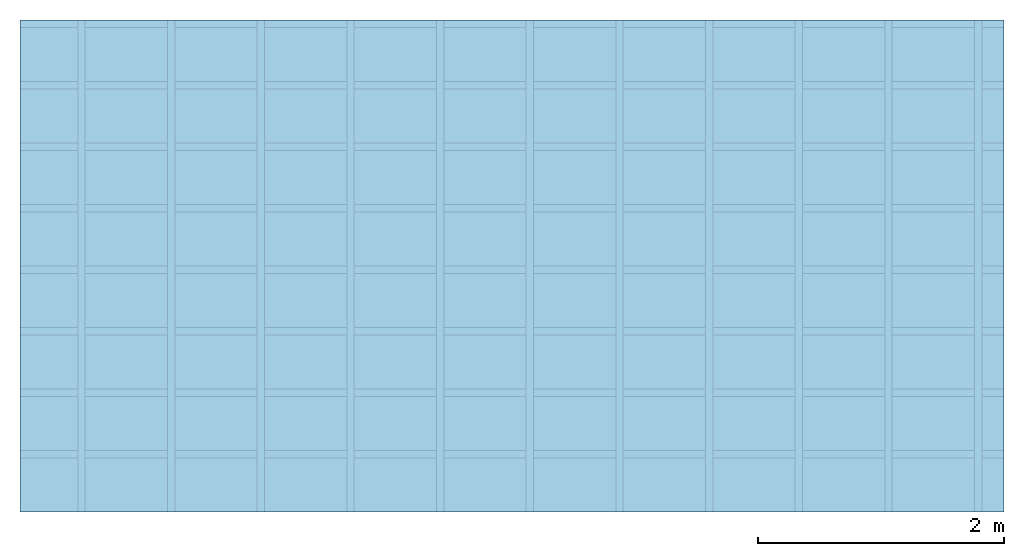
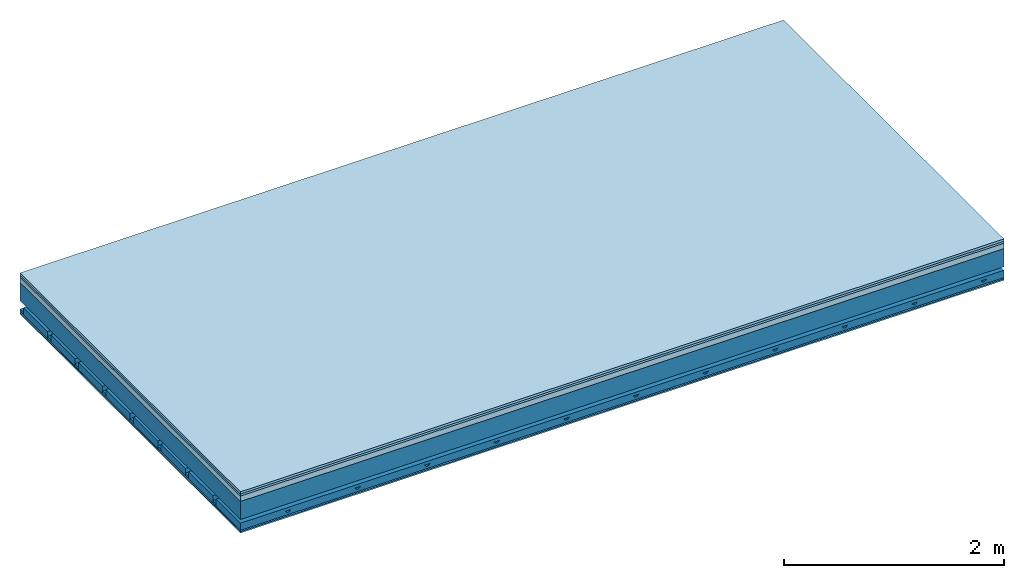
# One storey: 5 plates, 4 members, 1 element without a shape of its own.
"""IFC4 building model written with IfcOpenShell, lengths in metres."""

from ifc_helpers import new_model, si_unit, derived_unit, direction, frame, frame_2d, origin, origin_with_axes, place, context, project, spatial, polyline, rectangle, outline, extrude, material, layer, layer_set, type_object, element, aggregate, save


model = new_model("IFC4")

# Units and contexts
plan_context = context("Plan", 3, precision=1e-05, world=origin(), true_north=direction((0.0, 1.0)))
model_context = context("Model", 3, precision=1e-05, world=origin(), true_north=direction((0.0, 1.0)))
ifc_project = project(units=[si_unit("LENGTHUNIT", "METRE"), derived_unit("SOUNDPRESSUREUNIT", [(si_unit("PRESSUREUNIT", "PASCAL", prefix="MICRO"), 0)]), si_unit("ENERGYUNIT", "JOULE", prefix="MEGA"), si_unit("MASSUNIT", "GRAM", prefix="KILO"), derived_unit("THERMALTRANSMITTANCEUNIT", [(si_unit("POWERUNIT", "WATT"), 1), (si_unit("AREAUNIT", "SQUARE_METRE"), -1), (si_unit("THERMODYNAMICTEMPERATUREUNIT", "KELVIN"), -1)]), derived_unit("AREADENSITYUNIT", [(si_unit("MASSUNIT", "GRAM", prefix="KILO"), 1), (si_unit("AREAUNIT", "SQUARE_METRE"), -1)]), derived_unit("USERDEFINED", [(si_unit("ENERGYUNIT", "JOULE", prefix="MEGA"), 1), (si_unit("AREAUNIT", "SQUARE_METRE"), -1)])], contexts=[plan_context, model_context])

# Site, building, storey
site = spatial("IfcSite", under=ifc_project)
building_placement = place(None, origin())
building = spatial("IfcBuilding", under=site, at=building_placement)
storey_placement = place(building_placement, origin())
storey = spatial("IfcBuildingStorey", under=building, at=storey_placement)

# Slab, members, plates
ifc_material_1 = material(Name="Floor heating system Therm38 longitudinal", Category="03.007")
ifc_layer_1 = layer(ifc_material_1, 0.025, Name="On-material")
ifc_material_2 = material(Category="10.009")
ifc_layer_2 = layer(ifc_material_2, 0.022, Name="Impact sound insulation")
ifc_material_3 = material(Category="03.011")
ifc_layer_3 = layer(ifc_material_3, 0.06, Name="on Supporting structure")
ifc_layer_4 = layer(None, 0.2, Name="Supporting structure")
ifc_material_4 = material(Name="no composite action")
ifc_layer_5 = layer(ifc_material_4, 0.0, Name="Bond")
ifc_layer_6 = layer(None, 0.093, Name="Coupling")
ifc_layer_7 = layer(None, 0.027, Name="Battens / profiles")
ifc_material_5 = material(Category="03.007")
ifc_layer_8 = layer(ifc_material_5, 0.015, Name="Ceiling covering 1st layer")
ifc_layer_9 = layer(ifc_material_5, 0.015, Name="Ceiling covering layer 2")
ifc_material_6 = material(Name="Glued joints")
ifc_layer_10 = layer(ifc_material_6, 0.0, Name="Surface / treatment")
ifc_layer_set = layer_set([ifc_layer_1, ifc_layer_2, ifc_layer_3, ifc_layer_4, ifc_layer_5, ifc_layer_6, ifc_layer_7, ifc_layer_8, ifc_layer_9, ifc_layer_10])
slab_type = type_object("IfcSlabType", Name="A1161", PredefinedType="NOTDEFINED", material=ifc_layer_set)
slab_placement = place(None, frame((0.0, 0.0, 0.0), z_axis=(0.0, 0.0, -1.0), x_axis=(1.0, 0.0, 0.0)))
slab = element("IfcSlab", 1, at=slab_placement, inside=storey, type_object=slab_type, material=ifc_layer_set, Name="Slab #1")
ifc_material_7 = material()
member_1_placement = place(slab_placement, origin())
member_1 = element("IfcMember", 2, at=member_1_placement, material=ifc_material_7, Name="Supporting structure", context=plan_context, shape_type="SweptSolid", body=[
    extrude(rectangle(XDim=1.0, YDim=0.2, at=frame_2d((0.5, 0.1), x_axis=(1.0, 0.0))), frame((0.0, 4.0, 0.107), z_axis=(0.0, -1.0, 0.0), x_axis=(1.0, 0.0, 0.0)), (0.0, 0.0, 1.0), 4.0),
    extrude(rectangle(XDim=1.0, YDim=0.2, at=frame_2d((0.5, 0.1), x_axis=(1.0, 0.0))), frame((1.0, 4.0, 0.107), z_axis=(0.0, -1.0, 0.0), x_axis=(1.0, 0.0, 0.0)), (0.0, 0.0, 1.0), 4.0),
    extrude(rectangle(XDim=1.0, YDim=0.2, at=frame_2d((0.5, 0.1), x_axis=(1.0, 0.0))), frame((2.0, 4.0, 0.107), z_axis=(0.0, -1.0, 0.0), x_axis=(1.0, 0.0, 0.0)), (0.0, 0.0, 1.0), 4.0),
    extrude(rectangle(XDim=1.0, YDim=0.2, at=frame_2d((0.5, 0.1), x_axis=(1.0, 0.0))), frame((3.0, 4.0, 0.107), z_axis=(0.0, -1.0, 0.0), x_axis=(1.0, 0.0, 0.0)), (0.0, 0.0, 1.0), 4.0),
    extrude(rectangle(XDim=1.0, YDim=0.2, at=frame_2d((0.5, 0.1), x_axis=(1.0, 0.0))), frame((4.0, 4.0, 0.107), z_axis=(0.0, -1.0, 0.0), x_axis=(1.0, 0.0, 0.0)), (0.0, 0.0, 1.0), 4.0),
    extrude(rectangle(XDim=1.0, YDim=0.2, at=frame_2d((0.5, 0.1), x_axis=(1.0, 0.0))), frame((5.0, 4.0, 0.107), z_axis=(0.0, -1.0, 0.0), x_axis=(1.0, 0.0, 0.0)), (0.0, 0.0, 1.0), 4.0),
    extrude(rectangle(XDim=1.0, YDim=0.2, at=frame_2d((0.5, 0.1), x_axis=(1.0, 0.0))), frame((6.0, 4.0, 0.107), z_axis=(0.0, -1.0, 0.0), x_axis=(1.0, 0.0, 0.0)), (0.0, 0.0, 1.0), 4.0),
    extrude(rectangle(XDim=1.0, YDim=0.2, at=frame_2d((0.5, 0.1), x_axis=(1.0, 0.0))), frame((7.0, 4.0, 0.107), z_axis=(0.0, -1.0, 0.0), x_axis=(1.0, 0.0, 0.0)), (0.0, 0.0, 1.0), 4.0),
])
ifc_material_8 = material()
member_2_placement = place(slab_placement, origin())
member_2 = element("IfcMember", 3, at=member_2_placement, material=ifc_material_8, Name="Coupling", context=plan_context, shape_type="SweptSolid", body=[
    extrude(outline(polyline([(0.0, 0.0), (0.06, 0.0), (0.04, 0.02), (0.02, 0.02), (0.0, 0.0)])), frame((0.47, 4.0, 0.38), z_axis=(0.0, -1.0, 0.0), x_axis=(1.0, 0.0, 0.0)), (0.0, 0.0, 1.0), 4.0),
    extrude(outline(polyline([(0.0, 0.0), (0.06, 0.0), (0.04, 0.02), (0.02, 0.02), (0.0, 0.0)])), frame((1.199, 4.0, 0.38), z_axis=(0.0, -1.0, 0.0), x_axis=(1.0, 0.0, 0.0)), (0.0, 0.0, 1.0), 4.0),
    extrude(outline(polyline([(0.0, 0.0), (0.06, 0.0), (0.04, 0.02), (0.02, 0.02), (0.0, 0.0)])), frame((1.928, 4.0, 0.38), z_axis=(0.0, -1.0, 0.0), x_axis=(1.0, 0.0, 0.0)), (0.0, 0.0, 1.0), 4.0),
    extrude(outline(polyline([(0.0, 0.0), (0.06, 0.0), (0.04, 0.02), (0.02, 0.02), (0.0, 0.0)])), frame((2.657, 4.0, 0.38), z_axis=(0.0, -1.0, 0.0), x_axis=(1.0, 0.0, 0.0)), (0.0, 0.0, 1.0), 4.0),
    extrude(outline(polyline([(0.0, 0.0), (0.06, 0.0), (0.04, 0.02), (0.02, 0.02), (0.0, 0.0)])), frame((3.386, 4.0, 0.38), z_axis=(0.0, -1.0, 0.0), x_axis=(1.0, 0.0, 0.0)), (0.0, 0.0, 1.0), 4.0),
    extrude(outline(polyline([(0.0, 0.0), (0.06, 0.0), (0.04, 0.02), (0.02, 0.02), (0.0, 0.0)])), frame((4.115, 4.0, 0.38), z_axis=(0.0, -1.0, 0.0), x_axis=(1.0, 0.0, 0.0)), (0.0, 0.0, 1.0), 4.0),
    extrude(outline(polyline([(0.0, 0.0), (0.06, 0.0), (0.04, 0.02), (0.02, 0.02), (0.0, 0.0)])), frame((4.844, 4.0, 0.38), z_axis=(0.0, -1.0, 0.0), x_axis=(1.0, 0.0, 0.0)), (0.0, 0.0, 1.0), 4.0),
    extrude(outline(polyline([(0.0, 0.0), (0.06, 0.0), (0.04, 0.02), (0.02, 0.02), (0.0, 0.0)])), frame((5.573, 4.0, 0.38), z_axis=(0.0, -1.0, 0.0), x_axis=(1.0, 0.0, 0.0)), (0.0, 0.0, 1.0), 4.0),
    extrude(outline(polyline([(0.0, 0.0), (0.06, 0.0), (0.04, 0.02), (0.02, 0.02), (0.0, 0.0)])), frame((6.302, 4.0, 0.38), z_axis=(0.0, -1.0, 0.0), x_axis=(1.0, 0.0, 0.0)), (0.0, 0.0, 1.0), 4.0),
    extrude(outline(polyline([(0.0, 0.0), (0.06, 0.0), (0.04, 0.02), (0.02, 0.02), (0.0, 0.0)])), frame((7.031, 4.0, 0.38), z_axis=(0.0, -1.0, 0.0), x_axis=(1.0, 0.0, 0.0)), (0.0, 0.0, 1.0), 4.0),
    extrude(outline(polyline([(0.0, 0.0), (0.06, 0.0), (0.04, 0.02), (0.02, 0.02), (0.0, 0.0)])), frame((7.76, 4.0, 0.38), z_axis=(0.0, -1.0, 0.0), x_axis=(1.0, 0.0, 0.0)), (0.0, 0.0, 1.0), 4.0),
])
ifc_material_9 = material()
member_3_placement = place(slab_placement, origin())
member_3 = element("IfcMember", 4, at=member_3_placement, material=ifc_material_9, Name="Battens / profiles", context=plan_context, shape_type="SweptSolid", body=[
    extrude(rectangle(XDim=0.06, YDim=0.027, at=frame_2d((0.03, 0.0135), x_axis=(1.0, 0.0))), frame((0.0, 0.0, 0.4), z_axis=(1.0, 0.0, 0.0), x_axis=(0.0, 1.0, 0.0)), (0.0, 0.0, 1.0), 8.0),
    extrude(rectangle(XDim=0.06, YDim=0.027, at=frame_2d((0.03, 0.0135), x_axis=(1.0, 0.0))), frame((0.0, 0.5, 0.4), z_axis=(1.0, 0.0, 0.0), x_axis=(0.0, 1.0, 0.0)), (0.0, 0.0, 1.0), 8.0),
    extrude(rectangle(XDim=0.06, YDim=0.027, at=frame_2d((0.03, 0.0135), x_axis=(1.0, 0.0))), frame((0.0, 1.0, 0.4), z_axis=(1.0, 0.0, 0.0), x_axis=(0.0, 1.0, 0.0)), (0.0, 0.0, 1.0), 8.0),
    extrude(rectangle(XDim=0.06, YDim=0.027, at=frame_2d((0.03, 0.0135), x_axis=(1.0, 0.0))), frame((0.0, 1.5, 0.4), z_axis=(1.0, 0.0, 0.0), x_axis=(0.0, 1.0, 0.0)), (0.0, 0.0, 1.0), 8.0),
    extrude(rectangle(XDim=0.06, YDim=0.027, at=frame_2d((0.03, 0.0135), x_axis=(1.0, 0.0))), frame((0.0, 2.0, 0.4), z_axis=(1.0, 0.0, 0.0), x_axis=(0.0, 1.0, 0.0)), (0.0, 0.0, 1.0), 8.0),
    extrude(rectangle(XDim=0.06, YDim=0.027, at=frame_2d((0.03, 0.0135), x_axis=(1.0, 0.0))), frame((0.0, 2.5, 0.4), z_axis=(1.0, 0.0, 0.0), x_axis=(0.0, 1.0, 0.0)), (0.0, 0.0, 1.0), 8.0),
    extrude(rectangle(XDim=0.06, YDim=0.027, at=frame_2d((0.03, 0.0135), x_axis=(1.0, 0.0))), frame((0.0, 3.0, 0.4), z_axis=(1.0, 0.0, 0.0), x_axis=(0.0, 1.0, 0.0)), (0.0, 0.0, 1.0), 8.0),
    extrude(rectangle(XDim=0.06, YDim=0.027, at=frame_2d((0.03, 0.0135), x_axis=(1.0, 0.0))), frame((0.0, 3.5, 0.4), z_axis=(1.0, 0.0, 0.0), x_axis=(0.0, 1.0, 0.0)), (0.0, 0.0, 1.0), 8.0),
])
ifc_material_10 = material()
member_4_placement = place(slab_placement, origin())
member_4 = element("IfcMember", 5, at=member_4_placement, material=ifc_material_10, Name="Cavity", context=plan_context, shape_type="SweptSolid", body=[
    extrude(rectangle(XDim=0.44, YDim=0.08, at=frame_2d((0.22, 0.04), x_axis=(1.0, 0.0))), frame((0.0, 0.06, 0.347), z_axis=(1.0, 0.0, 0.0), x_axis=(0.0, 1.0, 0.0)), (0.0, 0.0, 1.0), 8.0),
    extrude(rectangle(XDim=0.44, YDim=0.08, at=frame_2d((0.22, 0.04), x_axis=(1.0, 0.0))), frame((0.0, 0.56, 0.347), z_axis=(1.0, 0.0, 0.0), x_axis=(0.0, 1.0, 0.0)), (0.0, 0.0, 1.0), 8.0),
    extrude(rectangle(XDim=0.44, YDim=0.08, at=frame_2d((0.22, 0.04), x_axis=(1.0, 0.0))), frame((0.0, 1.06, 0.347), z_axis=(1.0, 0.0, 0.0), x_axis=(0.0, 1.0, 0.0)), (0.0, 0.0, 1.0), 8.0),
    extrude(rectangle(XDim=0.44, YDim=0.08, at=frame_2d((0.22, 0.04), x_axis=(1.0, 0.0))), frame((0.0, 1.56, 0.347), z_axis=(1.0, 0.0, 0.0), x_axis=(0.0, 1.0, 0.0)), (0.0, 0.0, 1.0), 8.0),
    extrude(rectangle(XDim=0.44, YDim=0.08, at=frame_2d((0.22, 0.04), x_axis=(1.0, 0.0))), frame((0.0, 2.06, 0.347), z_axis=(1.0, 0.0, 0.0), x_axis=(0.0, 1.0, 0.0)), (0.0, 0.0, 1.0), 8.0),
    extrude(rectangle(XDim=0.44, YDim=0.08, at=frame_2d((0.22, 0.04), x_axis=(1.0, 0.0))), frame((0.0, 2.56, 0.347), z_axis=(1.0, 0.0, 0.0), x_axis=(0.0, 1.0, 0.0)), (0.0, 0.0, 1.0), 8.0),
    extrude(rectangle(XDim=0.44, YDim=0.08, at=frame_2d((0.22, 0.04), x_axis=(1.0, 0.0))), frame((0.0, 3.06, 0.347), z_axis=(1.0, 0.0, 0.0), x_axis=(0.0, 1.0, 0.0)), (0.0, 0.0, 1.0), 8.0),
    extrude(rectangle(XDim=0.44, YDim=0.08, at=frame_2d((0.22, 0.04), x_axis=(1.0, 0.0))), frame((0.0, 3.56, 0.347), z_axis=(1.0, 0.0, 0.0), x_axis=(0.0, 1.0, 0.0)), (0.0, 0.0, 1.0), 8.0),
])
plate_1_placement = place(slab_placement, origin())
plate_1 = element("IfcPlate", 6, at=plate_1_placement, material=ifc_material_1, Name="On-material", context=plan_context, shape_type="SweptSolid", body=[
    extrude(rectangle(XDim=8.0, YDim=4.0, at=frame_2d((4.0, 2.0), x_axis=(1.0, 0.0))), origin_with_axes(), (0.0, 0.0, 1.0), 0.025),
])
plate_2_placement = place(slab_placement, origin())
plate_2 = element("IfcPlate", 7, at=plate_2_placement, material=ifc_material_2, Name="Impact sound insulation", context=plan_context, shape_type="SweptSolid", body=[
    extrude(rectangle(XDim=8.0, YDim=4.0, at=frame_2d((4.0, 2.0), x_axis=(1.0, 0.0))), frame((0.0, 0.0, 0.025), z_axis=(0.0, 0.0, 1.0), x_axis=(1.0, 0.0, 0.0)), (0.0, 0.0, 1.0), 0.022),
])
plate_3_placement = place(slab_placement, origin())
plate_3 = element("IfcPlate", 8, at=plate_3_placement, material=ifc_material_3, Name="on Supporting structure", context=plan_context, shape_type="SweptSolid", body=[
    extrude(rectangle(XDim=8.0, YDim=4.0, at=frame_2d((4.0, 2.0), x_axis=(1.0, 0.0))), frame((0.0, 0.0, 0.047), z_axis=(0.0, 0.0, 1.0), x_axis=(1.0, 0.0, 0.0)), (0.0, 0.0, 1.0), 0.06),
])
plate_4_placement = place(slab_placement, origin())
plate_4 = element("IfcPlate", 9, at=plate_4_placement, material=ifc_material_5, Name="Ceiling covering 1st layer", context=plan_context, shape_type="SweptSolid", body=[
    extrude(rectangle(XDim=8.0, YDim=4.0, at=frame_2d((4.0, 2.0), x_axis=(1.0, 0.0))), frame((0.0, 0.0, 0.427), z_axis=(0.0, 0.0, 1.0), x_axis=(1.0, 0.0, 0.0)), (0.0, 0.0, 1.0), 0.015),
])
plate_5_placement = place(slab_placement, origin())
plate_5 = element("IfcPlate", 10, at=plate_5_placement, material=ifc_material_5, Name="Ceiling covering layer 2", context=plan_context, shape_type="SweptSolid", body=[
    extrude(rectangle(XDim=8.0, YDim=4.0, at=frame_2d((4.0, 2.0), x_axis=(1.0, 0.0))), frame((0.0, 0.0, 0.442), z_axis=(0.0, 0.0, 1.0), x_axis=(1.0, 0.0, 0.0)), (0.0, 0.0, 1.0), 0.015),
])
aggregate(slab, [plate_1, plate_2, plate_3, member_1, member_2, member_3, member_4, plate_4, plate_5])

save(model, "model.ifc")
